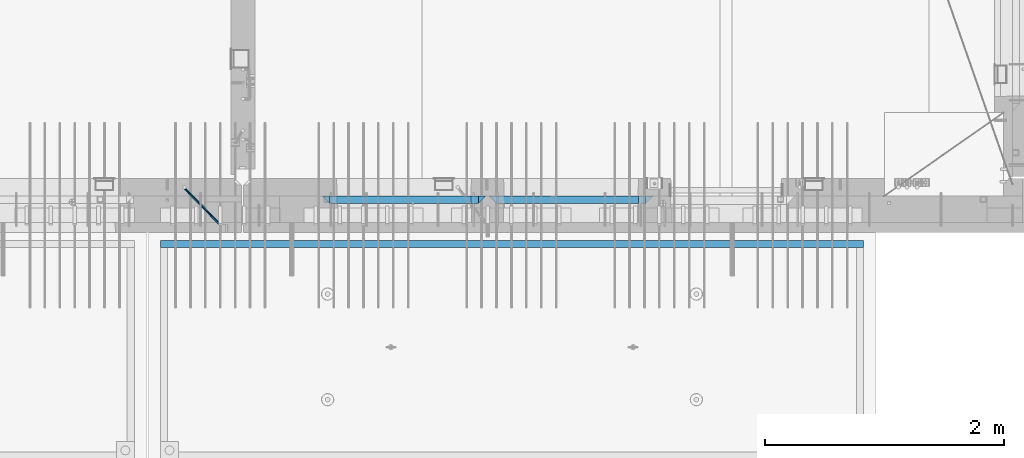
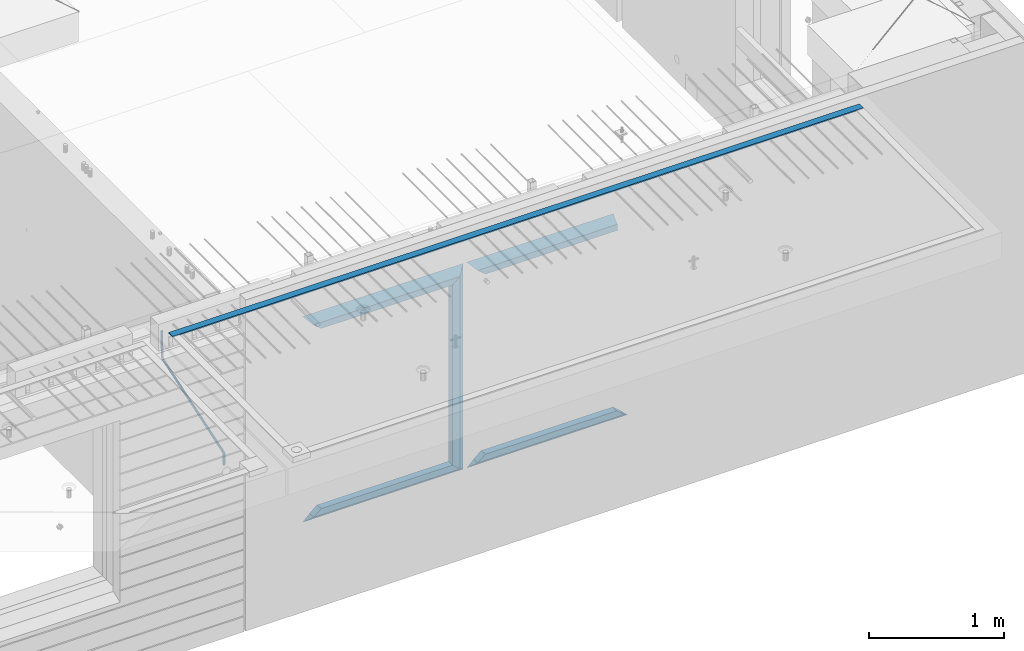
# One storey, part 93 of 341: 12 beams, 3 elements without a shape of their own.
"""IFC2X3 building model written with IfcOpenShell, lengths in millimetres."""

import ifcopenshell
import ifcopenshell.guid

model = None  # the IFC model being written
_history = None  # IfcOwnerHistory: only IFC2X3 demands one
_inside = {}  # id of a spatial element -> (the spatial element, [elements in it])
_under = {}  # id of a project, library or spatial element -> (it, [spatial elements below it])
_declared = {}  # id of a project -> (the project, [libraries it declares])
_typed = {}  # id of a type object -> (the type object, [elements of that type])
_made_of = {}  # id of a material, layer set ... -> (it, [elements and type objects made of it])


def new_model(schema):
    """Start an empty IFC model of exactly this schema.

    Asked for "IFC4X3", IfcOpenShell would pick the latest addendum, in which some entities
    have other attributes; the version numbers below select the first issue.
    IFC2X3 requires an IfcOwnerHistory on every rooted entity: one is made here for all.
    """
    global model, _history
    if schema == "IFC4X3":
        model = ifcopenshell.file(schema_version=(4, 3, 0, 0))
    else:
        model = ifcopenshell.file(schema=schema)
    _inside.clear()
    _under.clear()
    _declared.clear()
    _typed.clear()
    _made_of.clear()
    _history = None
    if model.schema == "IFC2X3":
        org = make("IfcOrganization", Name="unknown")
        user = make(
            "IfcPersonAndOrganization",
            ThePerson=make("IfcPerson", FamilyName="unknown"),
            TheOrganization=org,
        )
        app = make(
            "IfcApplication",
            ApplicationDeveloper=org,
            Version="unknown",
            ApplicationFullName="unknown",
            ApplicationIdentifier="unknown",
        )
        _history = make(
            "IfcOwnerHistory",
            OwningUser=user,
            OwningApplication=app,
            ChangeAction="ADDED",
            CreationDate=0,
        )
    return model


def make(cls, **values):
    """One entity of the class cls with the attributes given. An attribute that is None is left unset."""
    return model.create_entity(
        cls, **{name: value for name, value in values.items() if value is not None}
    )


def rooted(cls, **values):
    """An entity with a GlobalId (a new one), such as an element, a storey or a relation."""
    return make(cls, GlobalId=ifcopenshell.guid.new(), OwnerHistory=_history, **values)


def si_unit(unit_type, name, prefix=None):
    """IfcSIUnit, for example si_unit("LENGTHUNIT", "METRE", prefix="MILLI")."""
    return make("IfcSIUnit", UnitType=unit_type, Prefix=prefix, Name=name)


def assignment(units):
    """IfcUnitAssignment: the units of a project."""
    return None if units is None else make("IfcUnitAssignment", Units=units)


def point(xyz):
    """IfcCartesianPoint."""
    return None if xyz is None else make("IfcCartesianPoint", Coordinates=xyz)


def direction(xyz):
    """IfcDirection."""
    return None if xyz is None else make("IfcDirection", DirectionRatios=xyz)


def frame(location, z_axis=None, x_axis=None):
    """IfcAxis2Placement3D, a coordinate frame: its origin and axes. An axis left out is left unset."""
    return make(
        "IfcAxis2Placement3D",
        Location=point(location),
        Axis=direction(z_axis),
        RefDirection=direction(x_axis),
    )


def origin_with_axes():
    """The frame at (0, 0, 0) with the z axis (0, 0, 1) and the x axis (1, 0, 0) written out."""
    return frame((0.0, 0.0, 0.0), z_axis=(0.0, 0.0, 1.0), x_axis=(1.0, 0.0, 0.0))


def place(relative_to, where):
    """IfcLocalPlacement: puts the frame where relative to a parent placement (None: the world)."""
    return make(
        "IfcLocalPlacement", PlacementRelTo=relative_to, RelativePlacement=where
    )


def context(
    kind, dimensions, precision=None, world=None, true_north=None, identifier=None
):
    """IfcGeometricRepresentationContext, for example the 3D "Model" context."""
    return make(
        "IfcGeometricRepresentationContext",
        ContextIdentifier=identifier,
        ContextType=kind,
        CoordinateSpaceDimension=dimensions,
        Precision=precision,
        WorldCoordinateSystem=world,
        TrueNorth=true_north,
    )


def subcontext(parent, identifier, kind, view, scale=None):
    """IfcGeometricRepresentationSubContext, for example "Body" below "Model"."""
    return make(
        "IfcGeometricRepresentationSubContext",
        ContextIdentifier=identifier,
        ContextType=kind,
        ParentContext=parent,
        TargetScale=scale,
        TargetView=view,
    )


def project(units=None, contexts=None):
    """IfcProject with its units and contexts."""
    return rooted(
        "IfcProject",
        Name="project",
        RepresentationContexts=contexts,
        UnitsInContext=assignment(units),
    )


def spatial(cls, under=None, at=None, **own):
    """A site, building, storey or space (cls), placed at a placement, below another one or the project."""
    s = rooted(cls, ObjectPlacement=at, **own)
    if under is not None:
        _under.setdefault(under.id(), (under, []))[1].append(s)
    return s


def faces_of(points, faces, orient=None, outer=None):
    """IfcFace entities. A face is a list of loops; a loop is a list of indices into points, from 0.

    orient and outer hold one flag for each loop. By default every Orientation is true, the
    first loop of a face is its IfcFaceOuterBound and the others are IfcFaceBound.
    """
    made = []
    for i, loops in enumerate(faces):
        bounds = []
        for j, loop in enumerate(loops):
            is_outer = j == 0 if outer is None else outer[i][j]
            bounds.append(
                make(
                    "IfcFaceOuterBound" if is_outer else "IfcFaceBound",
                    Bound=make("IfcPolyLoop", Polygon=[points[k] for k in loop]),
                    Orientation=True if orient is None else orient[i][j],
                )
            )
        made.append(make("IfcFace", Bounds=bounds))
    return made


def faceted_brep(points, faces, orient=None, outer=None, voids=None):
    """IfcFacetedBrep: a solid bounded by flat faces; with voids (closed shells), ...WithVoids."""
    shared = [point(p) for p in points]
    hull = make("IfcClosedShell", CfsFaces=faces_of(shared, faces, orient, outer))
    if voids is None:
        return make("IfcFacetedBrep", Outer=hull)
    return make(
        "IfcFacetedBrepWithVoids",
        Outer=hull,
        Voids=[
            make(cls, CfsFaces=faces_of(shared, fs, o, b)) for cls, fs, o, b in voids
        ],
    )


def shape(context_of_items, identifier, shape_type, items):
    """IfcShapeRepresentation: the items that make up one representation, for example the "Body"."""
    return make(
        "IfcShapeRepresentation",
        ContextOfItems=context_of_items,
        RepresentationIdentifier=identifier,
        RepresentationType=shape_type,
        Items=items,
    )


def material(Name=None, Category=None):
    """IfcMaterial."""
    return make("IfcMaterial", Name=Name, Category=Category)


def made_of(thing, what):
    """Note that an element or type object is made of a material, layer set ...; save() writes the relation."""
    if what is not None:
        _made_of.setdefault(what.id(), (what, []))[1].append(thing)
    return thing


def type_object(cls, material=None, **own):
    """A type object (cls), such as IfcWallType, which elements share."""
    return made_of(rooted(cls, **own), material)


def element(
    cls,
    number,
    at=None,
    inside=None,
    cuts=None,
    type_object=None,
    material=None,
    context=None,
    identifier="Body",
    shape_type=None,
    held_by="IfcProductDefinitionShape",
    body=None,
    shapes=None,
    **own,
):
    """One element of the class cls, such as IfcWall. Its Tag is "e" and its number.

    at: its placement. inside: the storey or other place that contains it. cuts: it is an
    opening in that element (IfcRelVoidsElement). A single representation is given by context,
    identifier, shape_type and body (its items); several are given by shapes. held_by: the class
    of the entity that holds the representations. save() writes the other relations.
    """
    e = rooted(cls, Tag="e%d" % number, ObjectPlacement=at, **own)
    if body is not None:
        shapes = [shape(context, identifier, shape_type, body)]
    if shapes is not None:
        e.Representation = make(held_by, Representations=shapes)
    if inside is not None:
        _inside.setdefault(inside.id(), (inside, []))[1].append(e)
    if cuts is not None:
        rooted(
            "IfcRelVoidsElement", RelatingBuildingElement=cuts, RelatedOpeningElement=e
        )
    if type_object is not None:
        _typed.setdefault(type_object.id(), (type_object, []))[1].append(e)
    return made_of(e, material)


def aggregate(whole, parts):
    """IfcRelAggregates: a whole, such as a stair, and the parts it consists of."""
    return rooted("IfcRelAggregates", RelatingObject=whole, RelatedObjects=parts)


def save(model, path):
    """Write the relations noted so far, then the file.

    IfcRelAggregates (storeys below a building ...), IfcRelContainedInSpatialStructure (elements
    in a storey), IfcRelDefinesByType, IfcRelAssociatesMaterial and IfcRelDeclares: one each for
    every whole, place, type object, material and project.
    """
    for whole, parts in _under.values():
        aggregate(whole, parts)
    for where, things in _inside.values():
        rooted(
            "IfcRelContainedInSpatialStructure",
            RelatedElements=things,
            RelatingStructure=where,
        )
    for kind, things in _typed.values():
        rooted("IfcRelDefinesByType", RelatedObjects=things, RelatingType=kind)
    for what, things in _made_of.values():
        rooted("IfcRelAssociatesMaterial", RelatedObjects=things, RelatingMaterial=what)
    for by, libraries in _declared.values():
        rooted("IfcRelDeclares", RelatingContext=by, RelatedDefinitions=libraries)
    model.write(path)


model = new_model("IFC2X3")

# Units and contexts
model_context = context("Model", 3, precision=1e-05, world=origin_with_axes())
body_context = subcontext(model_context, "Body", "Model", "MODEL_VIEW")
ifc_project = project(units=[si_unit("LENGTHUNIT", "METRE", prefix="MILLI"), si_unit("AREAUNIT", "SQUARE_METRE"), si_unit("VOLUMEUNIT", "CUBIC_METRE"), si_unit("MASSUNIT", "GRAM", prefix="KILO"), si_unit("TIMEUNIT", "SECOND"), si_unit("PLANEANGLEUNIT", "RADIAN"), si_unit("SOLIDANGLEUNIT", "STERADIAN"), si_unit("THERMODYNAMICTEMPERATUREUNIT", "DEGREE_CELSIUS"), si_unit("LUMINOUSINTENSITYUNIT", "LUMEN")], contexts=[model_context])

# Site, building, storey
site_placement = place(None, origin_with_axes())
site = spatial("IfcSite", under=ifc_project, at=site_placement, CompositionType="ELEMENT")
building_placement = place(site_placement, origin_with_axes())
building = spatial("IfcBuilding", under=site, at=building_placement, CompositionType="ELEMENT")
storey_placement = place(building_placement, origin_with_axes())
storey = spatial("IfcBuildingStorey", under=building, at=storey_placement, Name="5", CompositionType="ELEMENT", Elevation=0.0)

# Assembly, beam
assembly_1_placement = place(storey_placement, origin_with_axes())
assembly_1 = element("IfcElementAssembly", 1, at=assembly_1_placement, inside=storey, AssemblyPlace="NOTDEFINED", PredefinedType="REINFORCEMENT_UNIT")
ifc_material_1 = material()
beam_type_1 = type_object("IfcBeamType", Name="D20", PredefinedType="NOTDEFINED")
beam_1_placement = place(assembly_1_placement, frame((28120.0219996506, 7924.99999995055, 96407.5), z_axis=(-0.000415599999849952, -0.999999913638316, 0.0), x_axis=(-0.00018169900008877, 0.0, -0.999999983492737)))
beam_1 = element("IfcBeam", 2, at=beam_1_placement, type_object=beam_type_1, material=ifc_material_1, Name="JM20", ObjectType="D20", context=body_context, shape_type="Brep", body=[
    faceted_brep([(-0.00060564729210455, -9.99999998165731, 0.0), (-0.000428079845733009, -7.07106779890455, -7.07106781186667), (119.575515501536, -7.07830994756296, -7.07106481604933), (119.575337932896, -10.0072421307195, -3.43332612828817e-06), (0.0, 0.0, -10.0), (119.575943836026, -0.00724214867295814, -9.99999700418266), (0.00042843479604926, 7.07106779888636, -7.07106781186303), (119.57637202373, 7.06382565022977, -7.07106481604933), (0.00060564729210455, 9.99999998166459, 3.63797880709171e-12), (119.576549238118, 9.99275783300072, 2.99581552098971e-06), (0.000428079845733009, 7.07106779890819, 7.07106781186667), (119.576371669405, 7.06382565024978, 7.07107080768037), (0.0, 0.0, 10.0), (119.57594333493, -0.00724214864203532, 10.0000029958155), (-0.000428434810601175, -7.07106779888272, 7.07106781186667), (119.575515147211, -7.07830994754295, 7.07107080768037), (123.007838984922, -7.07805953274146, -6.96781646693489), (122.583416564885, -10.0070226667376, 0.0904895847234002), (123.182432386879, -0.00697902713727672, -9.89150957511447), (123.004922326727, 7.0640757898218, -6.96792996825661), (122.579291790258, 9.99297690664025, 0.09032907062101), (122.154869373029, 7.06401377197108, 7.14863512328429), (121.980275971029, -0.00706673364766175, 10.0723282314621), (122.157786031181, -7.0781215506031, 7.1487486246051), (232.991069545737, -7.0553235628031, -0.344989315878593), (232.56664713427, -9.98428669916029, 6.71331673826626), (233.165662947809, 0.0157569427356066, -3.26868242414184), (232.988152887861, 7.08681175970924, -0.345102817348561), (232.562522351524, 10.0157128766077, 6.71315622151724), (232.138099934426, 7.08674974201131, 13.7714622742333), (231.963506532353, 0.0156692364653281, 16.6951553824965), (232.141016592301, -7.05538558050466, 13.7715757757042), (248.076986635424, -5.5847993905918, 1.85861828010275), (247.029610002806, -8.57448599522468, 8.8259290931519), (244.875536996158, -5.81406760439131, 15.6317136598209), (242.87659436863, 1.07944012639928, 18.2892356835691), (242.20373560088, 8.06791386077748, 15.2417548051744), (243.251112233527, 11.0576004654249, 8.27444399212709), (245.405185240103, 8.29718207458427, 1.4686594254481), (247.40412786763, 1.40367434377549, -1.1888625983047), (260.566830172145, 5.47100196453175, 3.19131575132906), (262.023113325369, -1.27539050352425, 6.49949830426976), (256.884070167318, 11.8442033958454, 5.28851055269934), (253.132144174728, 14.110878827727, 11.5625744366826), (251.508879555811, 10.9432405336265, 18.3382458712176), (252.965162709021, 4.19684806558143, 21.6464284241465), (256.647922713819, -2.17635336575768, 19.5492336227662), (260.399848700399, -4.44302879667157, 13.2751697364092), (1011.72756124764, 322.959435794994, 337.688425673249), (1010.10429662876, 319.79179750097, 344.464097107826), (1010.27127809466, 329.705828263024, 334.380243120345), (1006.58851809015, 336.079029694381, 336.477437921801), (1002.83659209782, 338.345705126318, 342.751501805859), (1001.21332747894, 335.178066832297, 349.527173240437), (1002.66961063194, 328.431674364263, 352.835355793341), (1006.35237063644, 322.058472932906, 350.738160991886), (1012.15285167976, 323.143366902459, 337.876301685487), (1011.27592458235, 320.298507294498, 344.981674676291), (1011.36533099508, 330.178988123705, 334.863551186057), (1009.37468146477, 337.283999466545, 337.708251560521), (1007.34699858574, 340.296381647149, 344.744015910405), (1006.47007148832, 337.45152203918, 351.849388901209), (1007.25759217299, 330.415900817941, 354.862139400639), (1009.24824170329, 323.310889475106, 352.017439026175), (1012.6528516715, 323.14345775195, 337.876301647731), (1012.65336908352, 320.298757574768, 344.981674572278), (1012.65157305435, 330.179221832586, 334.863551088932), (1012.65028222866, 337.284594639881, 337.708251313175), (1012.64973534261, 340.297345149043, 344.744015509988), (1012.65025275464, 337.452644971851, 351.849388434534), (1012.65153137178, 330.416880891225, 354.862138993334), (1012.65282219746, 323.311508083931, 352.017438769089), (1117.44132683994, 323.162497711652, 337.876293734989), (1117.44184425197, 320.31779753447, 344.981666659536), (1117.44004822278, 330.198261792288, 334.863543176189), (1117.43875739709, 337.303634599582, 337.708243400433), (1117.43821051104, 340.316385108745, 344.744007597245), (1117.43872792307, 337.471684931556, 351.849380521792), (1117.44000654022, 330.435920850927, 354.862131080592), (1117.44129736591, 323.330548043632, 352.017430856347)], [[[0, 1, 2, 3]], [[1, 4, 5, 2]], [[4, 6, 7, 5]], [[6, 8, 9, 7]], [[8, 10, 11, 9]], [[10, 12, 13, 11]], [[12, 14, 15, 13]], [[14, 0, 3, 15]], [[14, 12, 10, 8, 6, 4, 1, 0]], [[3, 2, 16, 17]], [[2, 5, 18, 16]], [[5, 7, 19, 18]], [[7, 9, 20, 19]], [[9, 11, 21, 20]], [[11, 13, 22, 21]], [[13, 15, 23, 22]], [[15, 3, 17, 23]], [[17, 16, 24, 25]], [[16, 18, 26, 24]], [[18, 19, 27, 26]], [[19, 20, 28, 27]], [[20, 21, 29, 28]], [[21, 22, 30, 29]], [[22, 23, 31, 30]], [[23, 17, 25, 31]], [[25, 24, 32, 33]], [[31, 25, 33, 34]], [[30, 31, 34, 35]], [[29, 30, 35, 36]], [[28, 29, 36, 37]], [[27, 28, 37, 38]], [[26, 27, 38, 39]], [[24, 26, 39, 32]], [[39, 40, 41, 32]], [[38, 42, 40, 39]], [[37, 43, 42, 38]], [[36, 44, 43, 37]], [[35, 45, 44, 36]], [[34, 46, 45, 35]], [[33, 47, 46, 34]], [[32, 41, 47, 33]], [[47, 41, 48, 49]], [[41, 40, 50, 48]], [[40, 42, 51, 50]], [[42, 43, 52, 51]], [[43, 44, 53, 52]], [[44, 45, 54, 53]], [[45, 46, 55, 54]], [[46, 47, 49, 55]], [[49, 48, 56, 57]], [[48, 50, 58, 56]], [[50, 51, 59, 58]], [[51, 52, 60, 59]], [[52, 53, 61, 60]], [[53, 54, 62, 61]], [[54, 55, 63, 62]], [[55, 49, 57, 63]], [[57, 56, 64, 65]], [[56, 58, 66, 64]], [[58, 59, 67, 66]], [[59, 60, 68, 67]], [[60, 61, 69, 68]], [[61, 62, 70, 69]], [[62, 63, 71, 70]], [[63, 57, 65, 71]], [[65, 64, 72, 73]], [[64, 66, 74, 72]], [[66, 67, 75, 74]], [[67, 68, 76, 75]], [[68, 69, 77, 76]], [[69, 70, 78, 77]], [[70, 71, 79, 78]], [[71, 65, 73, 79]], [[74, 75, 76, 77, 78, 79, 73, 72]]]),
])
aggregate(assembly_1, [beam_1])

assembly_2_placement = place(storey_placement, origin_with_axes())
assembly_2 = element("IfcElementAssembly", 3, at=assembly_2_placement, inside=storey, AssemblyPlace="NOTDEFINED", PredefinedType="REINFORCEMENT_UNIT")
ifc_material_2 = material(Name="CONCRETE/Concrete_Undefined")
beam_type_2 = type_object("IfcBeamType", PredefinedType="NOTDEFINED")
beam_2_placement = place(assembly_2_placement, frame((33810.0034098489, 7449.93184428067, 96725.278844281), z_axis=(6.5298999993069e-05, -1.00000033840378e-09, 0.99999999786802), x_axis=(-0.999999997792817, 1.22639999974798e-05, 6.52989999859729e-05)))
beam_2 = element("IfcBeam", 4, at=beam_2_placement, type_object=beam_type_2, material=ifc_material_2, context=body_context, shape_type="Brep", body=[
    faceted_brep([(2.5465851649642e-11, 29.9999999999982, -4.99999999998545), (-2.91038304567337e-11, 29.9999999999982, 5.0), (5890.06001043805, 29.9999999999991, 5.00000000001455), (5890.06001043806, 30.0, -4.99999999998545), (-2.5465851649642e-11, -30.0000000000018, 5.0), (5890.06001043806, -30.0, 5.00000000001455), (2.72848410531878e-11, -30.0000000000018, -4.99999999998545), (5890.06001043806, -30.0, -5.0)], [[[0, 1, 2, 3]], [[1, 4, 5, 2]], [[4, 6, 7, 5]], [[6, 0, 3, 7]], [[5, 7, 3, 2]], [[6, 4, 1, 0]]]),
])
aggregate(assembly_2, [beam_2])

# Assembly, beams
assembly_3_placement = place(storey_placement, origin_with_axes())
assembly_3 = element("IfcElementAssembly", 5, at=assembly_3_placement, inside=storey, AssemblyPlace="NOTDEFINED", PredefinedType="REINFORCEMENT_UNIT")
ifc_material_3 = material(Name="CONCRETE/C35/45")
beam_type_3 = type_object("IfcBeamType", PredefinedType="NOTDEFINED")
beam_3_placement = place(assembly_3_placement, frame((30674.9996552717, 7820.0, 96145.0), z_axis=(0.0, 0.0, -1.0), x_axis=(1.0, 0.0, 0.0)))
beam_3 = element("IfcBeam", 6, at=beam_3_placement, type_object=beam_type_3, material=ifc_material_3, Name="SK", context=body_context, shape_type="Brep", body=[
    faceted_brep([(1249.99847412109, -30.0, 30.0), (1249.99847412109, -29.999999998452, -30.0), (1249.99847412109, 30.0, 30.0), (60.0000000000073, -30.0, 30.0), (0.0, -30.0, -30.0), (60.0000000000073, 30.0, 30.0)], [[[0, 1, 2]], [[1, 0, 3, 4]], [[2, 1, 4, 5]], [[0, 2, 5, 3]], [[5, 4, 3]]]),
])
beam_4_placement = place(assembly_3_placement, frame((30734.9996552717, 7820.0, 96085.0), z_axis=(0.0, 0.0, -1.0), x_axis=(1.0, 0.0, 0.0)))
beam_4 = element("IfcBeam", 7, at=beam_4_placement, type_object=beam_type_3, material=ifc_material_3, Name="SK", context=body_context, shape_type="Brep", body=[
    faceted_brep([(1189.99847412109, -30.0, 30.0), (1189.99847412109, -30.0, -30.0), (1189.99847412109, 30.0, -30.0), (1189.99847412109, 30.0, 30.0), (1184.32279844542, 30.0, 30.0), (1185.94442006704, -30.0, 30.0), (1184.32279844542, 29.999999998452, 25.6756756756804), (1185.94442006696, -29.999999998452, 24.0540540541406), (65.6741497967687, 29.999999998452, 25.6756756756804), (64.0525281752307, -29.999999998452, 24.0540540541406), (65.6741497967687, 29.999999998452, 26.2921283848846), (64.0525281752307, -29.999999998452, 24.9021669953072), (0.0, -30.0, -30.0), (0.0, 30.0, -30.0)], [[[0, 1, 2, 3]], [[0, 3, 4, 5]], [[5, 4, 6, 7]], [[7, 6, 8, 9]], [[9, 8, 10, 11]], [[1, 0, 5, 7, 9, 11, 12]], [[2, 1, 12, 13]], [[8, 6, 4, 3, 2, 13, 10]], [[10, 13, 12, 11]]]),
])
ifc_material_4 = material(Name="CONCRETE/C30/37")
beam_5_placement = place(assembly_3_placement, frame((32044.9981293928, 7820.0, 94350.0), z_axis=(0.0, 0.0, 1.0), x_axis=(-1.0, 3.00000001838171e-08, 0.0)))
beam_5 = element("IfcBeam", 8, at=beam_5_placement, type_object=beam_type_3, material=ifc_material_4, Name="SK", context=body_context, shape_type="Brep", body=[
    faceted_brep([(1309.99847412109, 30.0, 30.0), (1309.99847412109, -30.0, 30.0), (1369.99847412109, -30.0, -30.0), (0.0, -30.0, -30.0), (60.0000000000073, 30.0, 30.0), (60.0000000000073, -30.0, 30.0)], [[[0, 1, 2]], [[3, 4, 0, 2]], [[4, 5, 1, 0]], [[5, 3, 2, 1]], [[4, 3, 5]]]),
])
beam_6_placement = place(assembly_3_placement, frame((31984.9981293928, 7820.0, 94410.0), z_axis=(0.0, 0.0, 1.0), x_axis=(-1.0, 3.00000001838171e-08, 0.0)))
beam_6 = element("IfcBeam", 9, at=beam_6_placement, type_object=beam_type_3, material=ifc_material_4, Name="SK", context=body_context, shape_type="Brep", body=[
    faceted_brep([(1185.94594588314, -29.9999988381387, 24.0540541168593), (1184.32432432432, 29.9999988381387, 25.6756756756804), (65.6756756756768, 30.0, 25.6756756756804), (64.0540540540533, -30.0, 24.0540540540533), (1185.94594594586, -29.999999998452, 24.9021669952926), (1184.32432432433, 29.999999998452, 26.2921283848846), (1249.99847412109, -29.999999998452, -30.0), (1249.99847412109, 29.999999998452, -30.0), (0.0, -30.0, -30.0), (0.0, 30.0, -30.0), (65.6756756756768, 30.0, 26.293436281092), (64.0540540540533, -30.0, 24.9034748914419)], [[[0, 1, 2, 3]], [[1, 0, 4, 5]], [[5, 4, 6, 7]], [[8, 9, 7, 6]], [[2, 1, 5, 7, 9, 10]], [[3, 2, 10, 11]], [[6, 4, 0, 3, 11, 8]], [[8, 11, 10, 9]]]),
])
beam_7_placement = place(assembly_3_placement, frame((29275.0000367414, 7820.0, 96145.0), z_axis=(0.0, 0.0, -1.0), x_axis=(1.0, 0.0, 0.0)))
beam_7 = element("IfcBeam", 10, at=beam_7_placement, type_object=beam_type_3, material=ifc_material_3, Name="SK", context=body_context, shape_type="Brep", body=[
    faceted_brep([(60.0000000000073, 30.0, 30.0), (0.0, -30.0, -30.0), (60.0000000000073, -30.0, 30.0), (1370.00038146973, -30.0, -30.0), (1310.0003814697, -30.0, 30.0), (1310.0003814697, 30.0, 30.0)], [[[0, 1, 2]], [[2, 1, 3, 4]], [[0, 2, 4, 5]], [[1, 0, 5, 3]], [[3, 5, 4]]]),
])
beam_8_placement = place(assembly_3_placement, frame((29335.0000367414, 7820.0, 96085.0), z_axis=(0.0, 0.0, -1.0), x_axis=(1.0, 0.0, 0.0)))
beam_8 = element("IfcBeam", 11, at=beam_8_placement, type_object=beam_type_3, material=ifc_material_3, Name="SK", context=body_context, shape_type="Brep", body=[
    faceted_brep([(1185.94632735287, -29.9999988381387, 24.0540541168593), (1184.32470579405, 29.9999988381387, 25.6756756756804), (65.6760571454033, 29.9999988381387, 25.6756756756804), (64.0544355865859, -29.9999988381387, 24.0540541168593), (65.6760571454033, 29.9999988381387, 26.2937632551475), (64.0544355865859, -29.9999988381387, 24.9038019193104), (0.0, 30.0, -30.0), (0.0, -30.0, -30.0), (1250.00038146973, -29.9999988381387, -30.0), (1185.94632735287, -29.9999988381387, 24.9034749452549), (1184.32470579405, 29.9999988381387, 26.2934362810629), (1250.00038146973, 29.9999988381387, -30.0)], [[[0, 1, 2, 3]], [[3, 2, 4, 5]], [[5, 4, 6, 7]], [[0, 3, 5, 7, 8, 9]], [[1, 0, 9, 10]], [[6, 4, 2, 1, 10, 11]], [[7, 6, 11, 8]], [[8, 11, 10, 9]]]),
])
beam_9_placement = place(assembly_3_placement, frame((30615.0004182112, 7820.0, 96175.0), z_axis=(-1.0, 3.00000001838171e-08, 0.0), x_axis=(0.0, 0.0, -1.0)))
beam_9 = element("IfcBeam", 12, at=beam_9_placement, type_object=beam_type_3, material=ifc_material_3, Name="SK", context=body_context, shape_type="Brep", body=[
    faceted_brep([(60.0000000000073, 30.0, 30.0), (0.0, -30.0, -30.0), (60.0000000000073, -30.0, 30.0), (1855.0, -30.0, -30.0), (1795.00000000001, -30.0, 30.0), (1795.00000000001, 30.0, 30.0)], [[[0, 1, 2]], [[3, 4, 2, 1]], [[4, 5, 0, 2]], [[5, 3, 1, 0]], [[4, 3, 5]]]),
])
beam_10_placement = place(assembly_3_placement, frame((30645.0004182112, 7820.0, 94350.0), z_axis=(0.0, 0.0, 1.0), x_axis=(-1.0, 3.00000001838171e-08, 0.0)))
beam_10 = element("IfcBeam", 13, at=beam_10_placement, type_object=beam_type_3, material=ifc_material_4, Name="SK", context=body_context, shape_type="Brep", body=[
    faceted_brep([(1370.00038146973, -30.0, -30.0), (1310.0003814697, 30.0, 30.0), (1310.0003814697, -30.0, 30.0), (0.0, -30.0, -30.0), (60.0000000000073, 30.0, 30.0), (60.0000000000073, -30.0, 30.0)], [[[0, 1, 2]], [[3, 4, 1, 0]], [[4, 5, 2, 1]], [[5, 3, 0, 2]], [[4, 3, 5]]]),
])
beam_11_placement = place(assembly_3_placement, frame((30585.0004182112, 7820.0, 94410.0), z_axis=(0.0, 0.0, 1.0), x_axis=(-1.0, 3.00000001838171e-08, 0.0)))
beam_11 = element("IfcBeam", 14, at=beam_11_placement, type_object=beam_type_3, material=ifc_material_4, Name="SK", context=body_context, shape_type="Brep", body=[
    faceted_brep([(1185.94594588314, -29.9999988381387, 24.0540541168593), (1184.32432432432, 29.9999988381387, 25.6756756756804), (65.6756756756768, 30.0, 25.6756756756804), (64.0540540540533, -30.0, 24.0540540540533), (1185.94594588314, -29.9999988381387, 24.9038019193104), (1184.32432432432, 29.9999988381387, 26.2937632551329), (1250.00038146973, -29.9999988381387, -30.0), (1250.00038146973, 29.9999988381387, -30.0), (0.0, -30.0, -30.0), (0.0, 30.0, -30.0), (65.6756756756768, 30.0, 26.293436281092), (64.0540540540533, -30.0, 24.9034748914419)], [[[0, 1, 2, 3]], [[1, 0, 4, 5]], [[4, 6, 7, 5]], [[8, 9, 7, 6]], [[2, 1, 5, 7, 9, 10]], [[3, 2, 10, 11]], [[6, 4, 0, 3, 11, 8]], [[8, 11, 10, 9]]]),
])
beam_type_4 = type_object("IfcBeamType", PredefinedType="NOTDEFINED")
beam_12_placement = place(assembly_3_placement, frame((30550.0004182112, 7820.0, 96115.0), z_axis=(-1.0, 3.00000001838171e-08, 0.0), x_axis=(0.0, 0.0, -1.0)))
beam_12 = element("IfcBeam", 15, at=beam_12_placement, type_object=beam_type_4, material=ifc_material_3, Name="SK", context=body_context, shape_type="Brep", body=[
    faceted_brep([(0.0, -30.0, -35.0), (54.9034748914273, -30.0, 29.0540540540533), (56.2934362811066, 30.0, 30.6756756756768), (0.0, 30.0, -35.0), (1735.0, -30.0, -35.0), (1680.09652510857, -30.0, 29.0540540540533), (1678.70656371891, 30.0, 30.6756756756768), (1735.0, 30.0, -35.0)], [[[0, 1, 2, 3]], [[1, 0, 4, 5]], [[2, 1, 5, 6]], [[3, 2, 6, 7]], [[7, 4, 0, 3]], [[4, 7, 6, 5]]]),
])
aggregate(assembly_3, [beam_3, beam_4, beam_5, beam_6, beam_7, beam_8, beam_9, beam_12, beam_10, beam_11])

save(model, "model.ifc")
